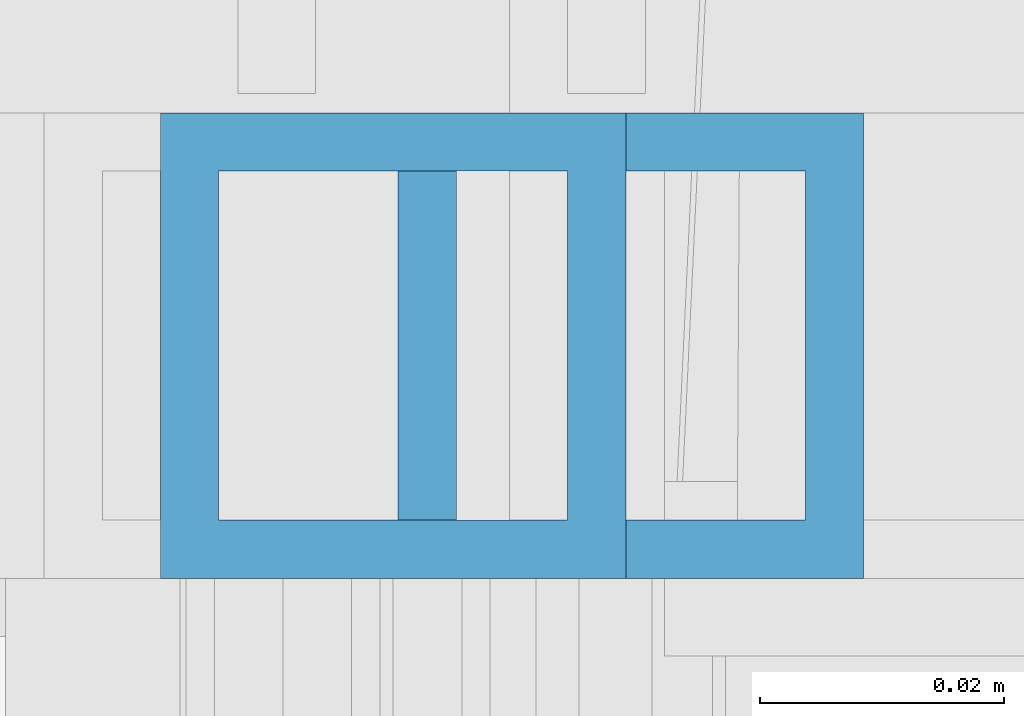
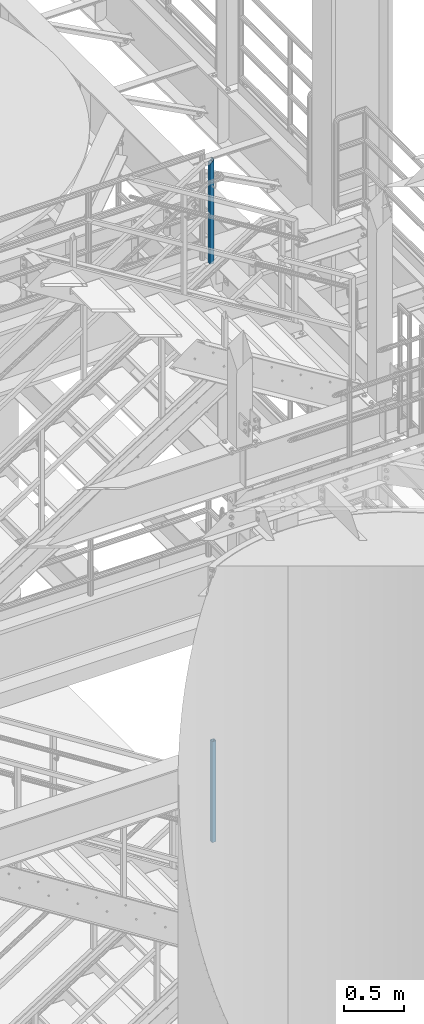
# One storey, part 648 of 1876: 2 columns, 2 elements without a shape of their own.
"""IFC2X3 building model written with IfcOpenShell, lengths in millimetres."""

from ifc_helpers import new_model, si_unit, frame, origin_with_axes, place, context, subcontext, project, spatial, faceted_brep, material, type_object, element, aggregate, save


model = new_model("IFC2X3")

# Units and contexts
model_context = context("Model", 3, precision=1e-05, world=origin_with_axes())
body_context = subcontext(model_context, "Body", "Model", "MODEL_VIEW")
ifc_project = project(units=[si_unit("LENGTHUNIT", "METRE", prefix="MILLI"), si_unit("AREAUNIT", "SQUARE_METRE"), si_unit("VOLUMEUNIT", "CUBIC_METRE"), si_unit("MASSUNIT", "GRAM", prefix="KILO"), si_unit("TIMEUNIT", "SECOND"), si_unit("PLANEANGLEUNIT", "RADIAN"), si_unit("SOLIDANGLEUNIT", "STERADIAN"), si_unit("THERMODYNAMICTEMPERATUREUNIT", "DEGREE_CELSIUS"), si_unit("LUMINOUSINTENSITYUNIT", "LUMEN")], contexts=[model_context])

# Site, building, storey
site_placement = place(None, origin_with_axes())
site = spatial("IfcSite", under=ifc_project, at=site_placement, CompositionType="ELEMENT")
building_placement = place(site_placement, origin_with_axes())
building = spatial("IfcBuilding", under=site, at=building_placement, Name="Undefined", CompositionType="ELEMENT")
storey_placement = place(building_placement, origin_with_axes())
storey = spatial("IfcBuildingStorey", under=building, at=storey_placement, Name="Undefined", CompositionType="ELEMENT", Elevation=0.0)

# Assembly, column
assembly_1_placement = place(storey_placement, origin_with_axes())
assembly_1 = element("IfcElementAssembly", 1, at=assembly_1_placement, inside=storey, Name="RAIL", AssemblyPlace="NOTDEFINED", PredefinedType="RIGID_FRAME")
ifc_material = material()
column_type = type_object("IfcColumnType", Name="HSS1-1/2X1-1/2X3/16", PredefinedType="NOTDEFINED")
column_1_placement = place(assembly_1_placement, frame((6166.24687501248, -4781.55000114554, 2329.68362061127), z_axis=(-1.0, 0.0, 0.0), x_axis=(0.0, 0.0, 1.0)))
column_1 = element("IfcColumn", 2, at=column_1_placement, type_object=column_type, material=ifc_material, Name="POST", ObjectType="HSS1-1/2X1-1/2X3/16", context=body_context, shape_type="Brep", body=[
    faceted_brep([(1022.350000765, -19.0499992349996, 19.0499992349996), (1022.35, -19.0499992349996, -19.0499992349996), (1022.35, 19.0499992349996, -19.0499992349996), (1022.350000765, 19.0499992349996, 19.0499992349996), (1022.35, -14.2874994260001, 14.2874994260001), (1022.35, 14.2874994260001, 14.2874994260001), (1022.35, 14.2874994260001, -14.2874994260001), (1022.35, -14.2874994260001, -14.2874994260001), (0.0, 19.0499992349996, 19.0499992349996), (0.0, -19.0499992349996, 19.0499992349996), (0.0, -19.0499992349996, -19.0499992350001), (0.0, 19.0499992349996, -19.0499992350001), (0.0, 14.2874994260001, 14.2874994260001), (0.0, -14.2874994260001, 14.2874994260001), (0.0, -14.2874994260001, -14.2874994260001), (0.0, 14.2874994260001, -14.2874994260001)], [[[0, 1, 2, 3], [4, 5, 6, 7]], [[8, 9, 0, 3]], [[10, 11, 2, 1]], [[9, 10, 1, 0]], [[11, 8, 3, 2]], [[10, 9, 8, 11], [12, 13, 14, 15]], [[14, 13, 4, 7]], [[15, 14, 7, 6]], [[12, 15, 6, 5]], [[13, 12, 5, 4]]]),
])
aggregate(assembly_1, [column_1])

assembly_2_placement = place(storey_placement, origin_with_axes())
assembly_2 = element("IfcElementAssembly", 3, at=assembly_2_placement, inside=storey, Name="RAIL", AssemblyPlace="NOTDEFINED", PredefinedType="RIGID_FRAME")
column_2_placement = place(assembly_2_placement, frame((6146.79999403856, -4781.55000114554, 8188.32499873524), z_axis=(-1.0, 0.0, 0.0), x_axis=(0.0, 0.0, 1.0)))
column_2 = element("IfcColumn", 4, at=column_2_placement, type_object=column_type, material=ifc_material, Name="POST", ObjectType="HSS1-1/2X1-1/2X3/16", context=body_context, shape_type="Brep", body=[
    faceted_brep([(0.0, 14.2874994260001, -14.2874994260001), (0.0, -14.2874994260001, -14.2874994260001), (1046.16249942132, -14.2874994260001, -14.2874994260001), (1046.16249942132, 14.2874994260001, -14.2874994260001), (0.0, -14.2874994260001, 14.2874994260001), (1017.58750056932, -14.2874994260001, 14.2874994260001), (0.0, 14.2874994260001, 14.2874994260001), (1017.58750056932, 14.2874994260001, 14.2874994260001), (0.0, 19.0499992349996, -19.0499992350001), (0.0, 19.0499992349996, 19.0499992349996), (1012.82500076032, 19.0499992349996, 19.0499992349996), (1050.92499923032, 19.0499992349996, -19.0499992349996), (0.0, -19.0499992349996, 19.0499992349996), (1012.82500076032, -19.0499992349996, 19.0499992349996), (0.0, -19.0499992349996, -19.0499992350001), (1050.92499923032, -19.0499992349996, -19.0499992349996)], [[[0, 1, 2, 3]], [[1, 4, 5, 2]], [[4, 6, 7, 5]], [[6, 0, 3, 7]], [[8, 9, 10, 11]], [[9, 12, 13, 10]], [[12, 14, 15, 13]], [[14, 8, 11, 15]], [[13, 15, 11, 10], [5, 7, 3, 2]], [[14, 12, 9, 8], [6, 4, 1, 0]]]),
])
aggregate(assembly_2, [column_2])

save(model, "model.ifc")
